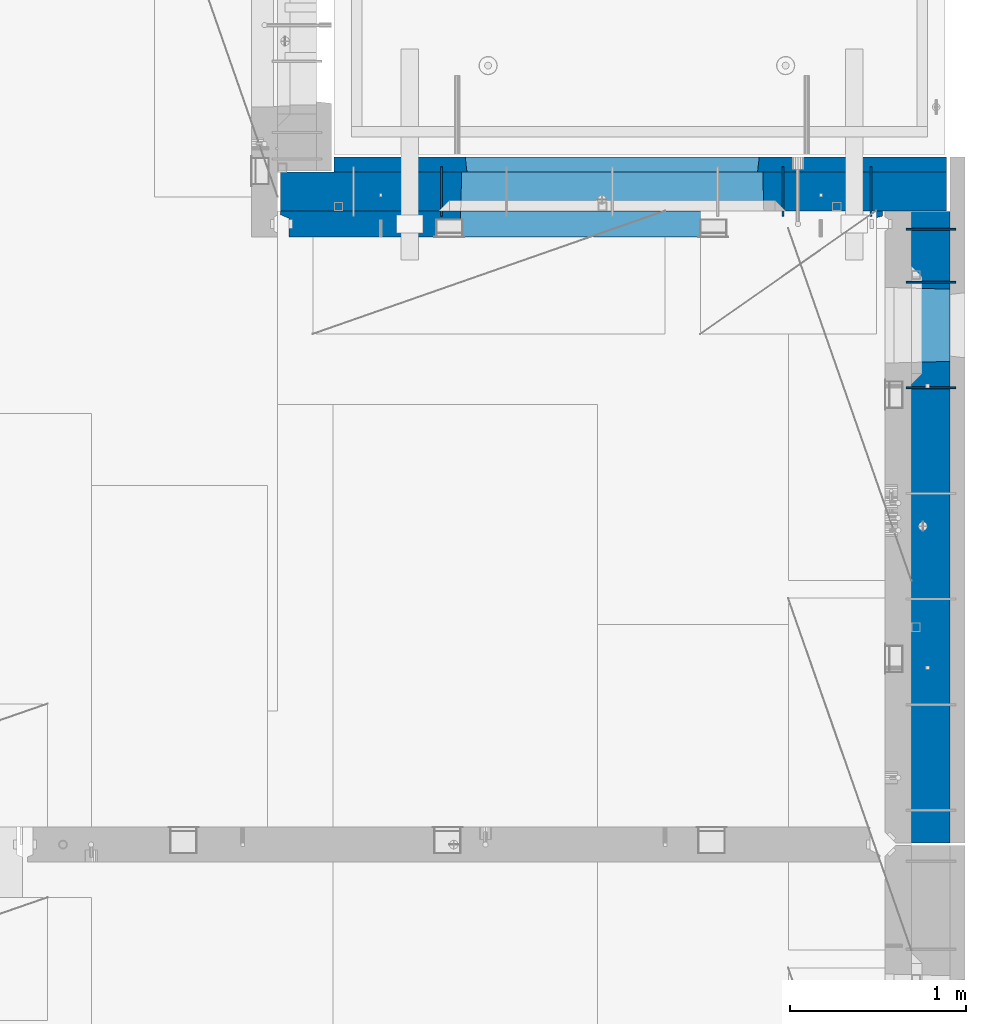
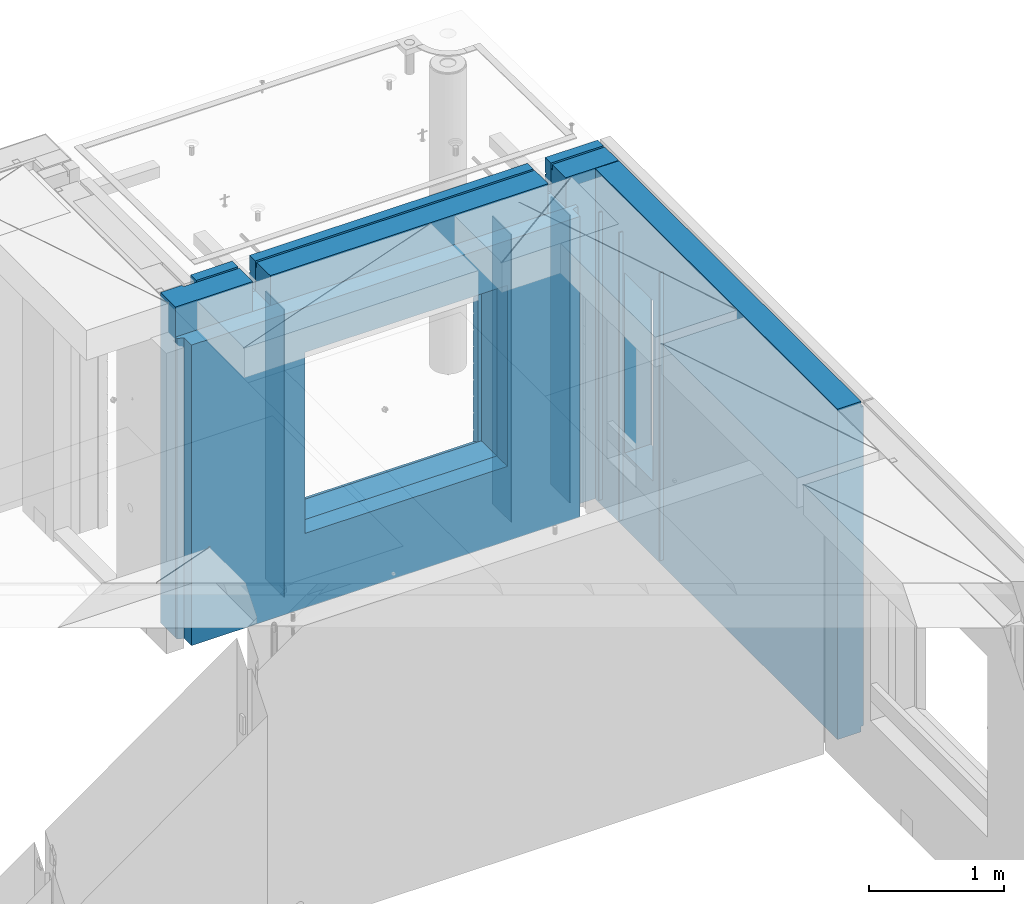
# One storey, part 243 of 350: 10 walls, 2 elements without a shape of their own.
"""IFC2X3 building model written with IfcOpenShell, lengths in millimetres."""

from ifc_helpers import new_model, si_unit, frame, origin_with_axes, place, context, subcontext, project, spatial, faceted_brep, material, type_object, element, aggregate, save


model = new_model("IFC2X3")

# Units and contexts
model_context = context("Model", 3, precision=1e-05, world=origin_with_axes())
body_context = subcontext(model_context, "Body", "Model", "MODEL_VIEW")
ifc_project = project(units=[si_unit("LENGTHUNIT", "METRE", prefix="MILLI"), si_unit("AREAUNIT", "SQUARE_METRE"), si_unit("VOLUMEUNIT", "CUBIC_METRE"), si_unit("MASSUNIT", "GRAM", prefix="KILO"), si_unit("TIMEUNIT", "SECOND"), si_unit("PLANEANGLEUNIT", "RADIAN"), si_unit("SOLIDANGLEUNIT", "STERADIAN"), si_unit("THERMODYNAMICTEMPERATUREUNIT", "DEGREE_CELSIUS"), si_unit("LUMINOUSINTENSITYUNIT", "LUMEN")], contexts=[model_context])

# Site, building, storey
site_placement = place(None, origin_with_axes())
site = spatial("IfcSite", under=ifc_project, at=site_placement, CompositionType="ELEMENT")
building_placement = place(site_placement, origin_with_axes())
building = spatial("IfcBuilding", under=site, at=building_placement, CompositionType="ELEMENT")
storey_placement = place(building_placement, origin_with_axes())
storey = spatial("IfcBuildingStorey", under=building, at=storey_placement, Name="2", CompositionType="ELEMENT", Elevation=0.0)

# Assembly, walls
assembly_1_placement = place(storey_placement, origin_with_axes())
assembly_1 = element("IfcElementAssembly", 1, at=assembly_1_placement, inside=storey, AssemblyPlace="NOTDEFINED", PredefinedType="REINFORCEMENT_UNIT")
ifc_material_1 = material(Name="Undefined")
wall_type_1 = type_object("IfcWallType", PredefinedType="NOTDEFINED")
wall_1_placement = place(assembly_1_placement, frame((34830.0, 20549.9951872276, 86115.0), z_axis=(0.0, 0.0, 1.0), x_axis=(0.0, 1.0, 0.0)))
wall_1 = element("IfcWall", 2, at=wall_1_placement, type_object=wall_type_1, material=ifc_material_1, Name="(PD)", context=body_context, shape_type="Brep", body=[
    faceted_brep([(0.0, 5.0, -1300.0), (0.0, 5.0, 1300.0), (280.0, 5.0, 1300.0), (280.0, 5.0, -1300.0), (0.0, -5.0, 1300.0), (280.0, -5.0, 1300.0), (0.0, -5.0, -1300.0), (280.0, -5.0, -1300.0)], [[[0, 1, 2, 3]], [[1, 4, 5, 2]], [[4, 6, 7, 5]], [[6, 0, 3, 7]], [[5, 7, 3, 2]], [[6, 4, 1, 0]]]),
])
wall_2_placement = place(assembly_1_placement, frame((34330.0, 20549.9951872276, 86115.0), z_axis=(0.0, 0.0, 1.0), x_axis=(0.0, 1.0, 0.0)))
wall_2 = element("IfcWall", 3, at=wall_2_placement, type_object=wall_type_1, material=ifc_material_1, Name="(PD)", context=body_context, shape_type="Brep", body=[
    faceted_brep([(0.0, 5.0, -1300.0), (0.0, 5.0, 1300.0), (280.0, 5.0, 1300.0), (280.0, 5.0, -1300.0), (0.0, -5.0, 1300.0), (280.0, -5.0, 1300.0), (0.0, -5.0, -1300.0), (280.0, -5.0, -1300.0)], [[[0, 1, 2, 3]], [[1, 4, 5, 2]], [[4, 6, 7, 5]], [[6, 0, 3, 7]], [[5, 7, 3, 2]], [[6, 4, 1, 0]]]),
])
wall_3_placement = place(assembly_1_placement, frame((32390.0, 20549.9951872276, 86115.0), z_axis=(0.0, 0.0, 1.0), x_axis=(0.0, 1.0, 0.0)))
wall_3 = element("IfcWall", 4, at=wall_3_placement, type_object=wall_type_1, material=ifc_material_1, Name="(PD)", context=body_context, shape_type="Brep", body=[
    faceted_brep([(0.0, 5.0, -1300.0), (0.0, 5.0, 1300.0), (280.0, 5.0, 1300.0), (280.0, 5.0, -1300.0), (0.0, -5.0, 1300.0), (280.0, -5.0, 1300.0), (0.0, -5.0, -1300.0), (280.0, -5.0, -1300.0)], [[[0, 1, 2, 3]], [[1, 4, 5, 2]], [[4, 6, 7, 5]], [[6, 0, 3, 7]], [[5, 7, 3, 2]], [[6, 4, 1, 0]]]),
])

assembly_2_placement = place(storey_placement, origin_with_axes())
assembly_2 = element("IfcElementAssembly", 5, at=assembly_2_placement, inside=storey, AssemblyPlace="NOTDEFINED", PredefinedType="REINFORCEMENT_UNIT")
wall_4_placement = place(assembly_2_placement, frame((35030.0, 20175.0002441406, 86115.0), z_axis=(0.0, 0.0, 1.0), x_axis=(1.0, 0.0, 0.0)))
wall_4 = element("IfcWall", 6, at=wall_4_placement, type_object=wall_type_1, material=ifc_material_1, Name="(PD)", context=body_context, shape_type="Brep", body=[
    faceted_brep([(0.0, 5.0, -1300.0), (0.0, 5.0, 1300.0), (280.0, 5.0, 1300.0), (280.0, 5.0, -1300.0), (0.0, -5.0, 1300.0), (280.0, -5.0, 1300.0), (0.0, -5.0, -1300.0), (280.0, -5.0, -1300.0)], [[[0, 1, 2, 3]], [[1, 4, 5, 2]], [[4, 6, 7, 5]], [[6, 0, 3, 7]], [[5, 7, 3, 2]], [[6, 4, 1, 0]]]),
])
wall_5_placement = place(assembly_2_placement, frame((35030.0, 20475.0002441406, 86115.0), z_axis=(0.0, 0.0, 1.0), x_axis=(1.0, 0.0, 0.0)))
wall_5 = element("IfcWall", 7, at=wall_5_placement, type_object=wall_type_1, material=ifc_material_1, Name="(PD)", context=body_context, shape_type="Brep", body=[
    faceted_brep([(0.0, 5.0, -1300.0), (0.0, 5.0, 1300.0), (280.0, 5.0, 1300.0), (280.0, 5.0, -1300.0), (0.0, -5.0, 1300.0), (280.0, -5.0, 1300.0), (0.0, -5.0, -1300.0), (280.0, -5.0, -1300.0)], [[[0, 1, 2, 3]], [[1, 4, 5, 2]], [[4, 6, 7, 5]], [[6, 0, 3, 7]], [[5, 7, 3, 2]], [[6, 4, 1, 0]]]),
])
wall_6_placement = place(assembly_2_placement, frame((35030.0, 19575.0002441406, 86115.0), z_axis=(0.0, 0.0, 1.0), x_axis=(1.0, 0.0, 0.0)))
wall_6 = element("IfcWall", 8, at=wall_6_placement, type_object=wall_type_1, material=ifc_material_1, Name="(PD)", context=body_context, shape_type="Brep", body=[
    faceted_brep([(0.0, 5.0, -1300.0), (0.0, 5.0, 1300.0), (280.0, 5.0, 1300.0), (280.0, 5.0, -1300.0), (0.0, -5.0, 1300.0), (280.0, -5.0, 1300.0), (0.0, -5.0, -1300.0), (280.0, -5.0, -1300.0)], [[[0, 1, 2, 3]], [[1, 4, 5, 2]], [[4, 6, 7, 5]], [[6, 0, 3, 7]], [[5, 7, 3, 2]], [[6, 4, 1, 0]]]),
])
ifc_material_2 = material(Name="COS5gt")
wall_type_2 = type_object("IfcWallType", PredefinedType="NOTDEFINED")
wall_7_placement = place(assembly_2_placement, frame((35170.0, 20575.0002441406, 86247.5), z_axis=(0.0, 0.0, 1.0), x_axis=(0.0, -1.0, 0.0)))
wall_7 = element("IfcWall", 9, at=wall_7_placement, type_object=wall_type_2, material=ifc_material_2, context=body_context, shape_type="Brep", body=[
    faceted_brep([(0.0, 90.0, 1492.5), (3585.0, 90.0, 1492.5), (3585.0, 90.0, 1442.5), (0.0, 90.0, 1442.5), (0.0, -110.0, 1492.5), (3585.0, -110.0, 1492.5), (3585.0, 110.0, 1442.5), (3585.0, -110.0, -1492.5), (3585.0, 90.0, -1492.5), (3585.0, 90.0, -1442.5), (3585.0, 110.0, -1442.5), (0.0, 110.0, 1442.5), (0.0, 90.0, -1492.5), (0.0, -110.0, -1492.5), (0.0, 110.0, -1442.5), (0.0, 90.0, -1442.5), (440.000277665298, 110.0, -807.5), (470.000277665298, 110.0, -807.5), (820.000277665298, 110.0, -807.5), (850.000277665298, 110.0, -807.5), (850.000277665298, 110.0, -802.5), (850.000277665298, 110.0, 807.5), (440.000277665298, 110.0, 807.5), (440.000277665298, 110.0, -802.5), (855.946223611245, -110.0, -813.445945945947), (855.946223611245, -110.0, 813.445945945947), (434.054331719351, -110.0, -813.445945945947), (434.054331719351, -110.0, 813.445945945947)], [[[0, 1, 2, 3]], [[4, 5, 1, 0]], [[6, 2, 1, 5, 7, 8, 9, 10]], [[11, 3, 2, 6]], [[12, 13, 4, 0, 3, 11, 14, 15]], [[7, 13, 12, 8]], [[15, 9, 8, 12]], [[14, 10, 9, 15]], [[11, 6, 10, 14], [16, 17, 18, 19, 20, 21, 22, 23]], [[20, 19, 24, 25, 21]], [[18, 17, 16, 26, 24, 19]], [[23, 22, 27, 26, 16]], [[21, 25, 27, 22]], [[4, 13, 7, 5], [24, 26, 27, 25]]]),
])
aggregate(assembly_2, [wall_4, wall_5, wall_6, wall_7])

# Wall
wall_8_placement = place(assembly_1_placement, frame((31475.0, 20689.9951872276, 86247.5), z_axis=(0.0, 0.0, 1.0), x_axis=(1.0, 0.0, 0.0)))
wall_8 = element("IfcWall", 10, at=wall_8_placement, type_object=wall_type_2, material=ifc_material_2, context=body_context, shape_type="Brep", body=[
    faceted_brep([(810.0, 110.0, 1442.5), (810.0, 90.0, 1442.5), (3185.0, 90.0, 1442.5), (3185.0, 110.0, 1442.5), (810.0, 90.0, 1492.5), (810.0, -110.0, 1492.5), (3185.0, -110.0, 1492.5), (3185.0, 90.0, 1492.5), (184.0, 90.0, 1442.5), (184.0, 90.0, 1492.5), (660.0, 90.0, 1492.5), (660.0, 90.0, 1442.5), (184.0, 110.0, 1492.5), (184.0, 110.0, 1442.5), (0.0, 110.0, 1492.5), (0.0, -110.0, 1492.5), (660.0, -110.0, 1492.5), (0.0, -110.0, -1492.5), (0.0, 110.0, -1492.5), (3785.0, 90.0, -1492.5), (184.0, 90.0, -1492.5), (184.0, 90.0, -1442.5), (3785.0, 90.0, -1442.5), (3785.0, -110.0, -1492.5), (184.0, 110.0, -1492.5), (184.0, 110.0, -1442.5), (3785.0, 110.0, -1442.5), (3785.0, 110.0, 1442.5), (3785.0, 90.0, 1442.5), (3785.0, 90.0, 1492.5), (3785.0, -110.0, 1492.5), (3335.0, 90.0, 1492.5), (3335.0, -110.0, 1492.5), (3185.0, -110.000000000004, 1222.5), (810.0, -110.0, 1222.5), (660.0, -110.0, 1222.5), (3335.0, -110.000000000004, 1222.5), (1024.05429979644, -110.000000000004, -813.445945945947), (1024.05429979644, -110.000000000004, 813.445945945947), (2745.94619168834, -110.000000000004, 813.445945945947), (2745.94619168834, -110.000000000004, -813.445945945947), (1030.00024574239, 110.0, -802.5), (1030.00024574239, 110.0, 807.5), (1030.00024574239, 110.0, -807.5), (2740.00024574239, 110.0, -807.5), (2710.00024574239, 110.0, -807.5), (1060.00024574239, 110.0, -807.5), (2740.00024574239, 110.0, 807.5), (2740.00024574239, 110.0, -802.5), (660.0, 110.0, 1442.5), (660.0, 109.999999999996, 1222.5), (810.0, 109.999999999996, 1222.5), (3185.0, 109.999999999996, 1222.5), (3335.0, 109.999999999996, 1222.5), (3335.0, 110.0, 1442.5), (3335.0, 90.0, 1442.5)], [[[0, 1, 2, 3]], [[4, 5, 6, 7]], [[8, 9, 10, 11]], [[12, 9, 8, 13]], [[9, 12, 14, 15, 16, 10]], [[17, 15, 14, 18]], [[19, 20, 21, 22]], [[23, 17, 18, 24, 20, 19]], [[25, 21, 20, 24]], [[26, 22, 21, 25]], [[27, 28, 29, 30, 23, 19, 22, 26]], [[30, 29, 31, 32]], [[33, 6, 5, 34, 35, 16, 15, 17, 23, 30, 32, 36], [37, 38, 39, 40]], [[41, 42, 38, 37, 43]], [[40, 44, 45, 46, 43, 37]], [[39, 47, 48, 44, 40]], [[38, 42, 47, 39]], [[27, 26, 25, 24, 18, 14, 12, 13, 49, 50, 51, 0, 3, 52, 53, 54], [41, 43, 46, 45, 44, 48, 47, 42]], [[28, 27, 54, 55]], [[29, 28, 55, 31]], [[54, 53, 36, 32, 31, 55]], [[52, 33, 36, 53]], [[3, 2, 7, 6, 33, 52]], [[1, 4, 7, 2]], [[0, 51, 34, 5, 4, 1]], [[50, 35, 34, 51]], [[49, 11, 10, 16, 35, 50]], [[13, 8, 11, 49]]]),
])

ifc_material_3 = material(Name="CONCRETE/C30/37")
wall_type_3 = type_object("IfcWallType", PredefinedType="NOTDEFINED")
wall_9_placement = place(assembly_1_placement, frame((31780.0, 20842.4951872276, 86247.5), z_axis=(0.0, 0.0, 1.0), x_axis=(1.0, 0.0, 0.0)))
wall_9 = element("IfcWall", 11, at=wall_9_placement, type_object=wall_type_3, material=ifc_material_3, context=body_context, shape_type="Brep", body=[
    faceted_brep([(3480.0, -42.5, 1492.5), (3480.0, 42.5, 1492.5), (3030.0, 42.5, 1492.5), (3030.0, -42.5, 1492.5), (3480.0, 42.4999992431694, 1356.99999988925), (3030.0, 42.4999993410347, 1356.99999988925), (3480.0, 32.4999991127006, 1355.00000040044), (3480.0, 32.4999992507037, 1344.99999999926), (3030.0, 32.4999992507037, 1344.99999999926), (3030.0, 32.4999991127006, 1355.00000040044), (3480.0, 42.4999996036895, 1342.99999994476), (3030.0, 42.4999996549377, 1342.99999994476), (3480.0, 42.4999993831152, 892.999999944761), (0.0, 42.5, 892.999999944761), (0.0, 32.4999992507037, 894.999999999258), (3480.0, 32.4999992507037, 894.999999999258), (0.0, 32.4999991127006, 905.00000040044), (3480.0, 32.4999991127006, 905.00000040044), (3480.0, 42.4999992431694, 906.999999889245), (0.0, 42.5, 906.999999889245), (0.0, 42.5, 1042.99999994476), (3480.0, 42.4999994189675, 1042.99999994476), (0.0, 32.4999992507037, 1044.99999999926), (3480.0, 32.4999992507037, 1044.99999999926), (0.0, 32.4999991127006, 1055.00000040044), (3480.0, 32.4999991127006, 1055.00000040044), (3480.0, 42.4999992431694, 1056.99999988925), (0.0, 42.5, 1056.99999988925), (0.0, 42.5, 1192.99999994476), (3480.0, 42.4999994795144, 1192.99999994476), (0.0, 32.4999992507037, 1194.99999999926), (3480.0, 32.4999992507037, 1194.99999999926), (0.0, 32.4999991127006, 1205.00000040044), (3480.0, 32.4999991127006, 1205.00000040044), (3480.0, 42.4999992431694, 1206.99999988925), (0.0, 42.5, 1206.99999988925), (-3.63797880709171e-12, 32.4999992507037, 1344.99999999926), (-3.63797880709171e-12, 32.4999991127006, 1355.00000040044), (355.0, 32.4999991127006, 1355.00000040044), (355.0, 32.4999992507037, 1344.99999999926), (0.0, 42.5, 1342.99999994476), (355.0, 42.4999999595711, 1342.99999994476), (505.0, 32.4999992507037, 1344.99999999926), (505.0, 32.4999991127006, 1355.00000040044), (2880.0, 32.4999991127006, 1355.00000040044), (2880.0, 32.4999992507037, 1344.99999999926), (505.0, 42.4999999424908, 1342.99999994476), (2880.0, 42.4999996720217, 1342.99999994476), (355.0, 42.4999998715975, 1222.5), (505.0, 42.4999998467429, 1222.5), (2880.0, 42.4999994331811, 1222.5), (3030.0, 42.4999994081736, 1222.5), (355.0, -42.5, 1222.5), (505.0, -42.5, 1222.5), (505.0, 42.5, 1492.5), (505.0, 42.4999998901731, 1356.99999988925), (505.0, -42.5, 1492.5), (2880.0, -42.5, 1492.5), (2880.0, 42.5, 1492.5), (2880.0, 42.4999993736565, 1356.99999988925), (2880.0, -42.5000000000036, 1222.5), (3030.0, -42.5000000000036, 1222.5), (3480.0, -42.5, -1492.5), (3480.0, 42.5, -1492.5), (3480.0, 42.5, -1357.00000005524), (3480.0, 32.4999992507037, -1355.00000000074), (3480.0, 32.4999991127006, -1344.99999959956), (3480.0, 42.4999992431694, -1343.00000011075), (3480.0, 42.4999992794692, -1207.00000005524), (3480.0, 32.4999992507037, -1205.00000000074), (3480.0, 32.4999991127006, -1194.99999959956), (3480.0, 42.4999992431694, -1193.00000011075), (3480.0, 42.4999992814955, -1057.00000005524), (3480.0, 32.4999992507037, -1055.00000000074), (3480.0, 32.4999991127006, -1044.99999959956), (3480.0, 42.4999992431694, -1043.00000011075), (3480.0, 42.4999992837656, -907.000000055239), (3480.0, 32.4999992507037, -905.000000000742), (3480.0, 32.4999991127006, -894.99999959956), (3480.0, 42.4999992431694, -893.000000110755), (3480.0, 42.4999992863159, -757.000000055239), (3480.0, 32.4999992507037, -755.000000000742), (3480.0, 32.4999991127006, -744.99999959956), (3480.0, 42.4999992431694, -743.000000110755), (3480.0, 42.4999992892117, -607.000000055239), (3480.0, 32.4999992507037, -605.000000000742), (3480.0, 32.4999991127006, -594.99999959956), (3480.0, 42.4999992431694, -593.000000110755), (3480.0, 42.4999992925223, -457.000000055239), (3480.0, 32.4999992507037, -455.000000000742), (3480.0, 32.4999991127006, -444.99999959956), (3480.0, 42.4999992431694, -443.000000110755), (3480.0, 42.4999992963494, -307.000000055239), (3480.0, 32.4999992507037, -305.000000000742), (3480.0, 32.4999991127006, -294.99999959956), (3480.0, 42.4999992431694, -293.000000110755), (3480.0, 42.4999993008169, -157.000000055239), (3480.0, 32.4999992507037, -155.000000000742), (3480.0, 32.4999991127006, -144.99999959956), (3480.0, 42.4999992431694, -143.000000110755), (3480.0, 42.4999993061028, -7.00000005523907), (3480.0, 32.4999992507037, -5.00000000074215), (3480.0, 32.4999991127006, 5.0000004004396), (3480.0, 42.4999992431694, 6.99999988924537), (3480.0, 42.4999993124584, 142.999999944761), (3480.0, 32.4999992507037, 144.999999999258), (3480.0, 32.4999991127006, 155.00000040044), (3480.0, 42.4999992431694, 156.999999889245), (3480.0, 42.49999932024, 292.999999944761), (3480.0, 32.4999992507037, 294.999999999258), (3480.0, 32.4999991127006, 305.00000040044), (3480.0, 42.4999992431694, 306.999999889245), (3480.0, 42.4999993299934, 442.999999944761), (3480.0, 32.4999992507037, 444.999999999258), (3480.0, 32.4999991127006, 455.00000040044), (3480.0, 42.4999992431694, 456.999999889245), (3480.0, 42.4999993425699, 592.999999944761), (3480.0, 32.4999992507037, 594.999999999258), (3480.0, 32.4999991127006, 605.00000040044), (3480.0, 42.4999992431694, 606.999999889245), (3480.0, 42.4999993594065, 742.999999944761), (3480.0, 32.4999992507037, 744.999999999258), (3480.0, 32.4999991127006, 755.00000040044), (3480.0, 42.4999992431694, 756.999999889245), (0.0, -42.5, -1492.5), (0.0, 42.5, -1492.5), (0.0, 42.5, -1357.00000005524), (0.0, 32.4999992507037, -1355.00000000074), (0.0, 32.4999991127006, -1344.99999959956), (0.0, 42.5, -1343.00000011075), (0.0, 42.5, -1207.00000005524), (0.0, 32.4999992507037, -1205.00000000074), (0.0, 32.4999991127006, -1194.99999959956), (0.0, 42.5, -1193.00000011075), (0.0, 42.5, -1057.00000005524), (0.0, 32.4999992507037, -1055.00000000074), (0.0, 32.4999991127006, -1044.99999959956), (0.0, 42.5, -1043.00000011075), (0.0, 42.5, -907.000000055239), (0.0, 32.4999992507037, -905.000000000742), (0.0, 32.4999991127006, -894.99999959956), (0.0, 42.5, -893.000000110755), (0.0, 32.4999991127006, 755.00000040044), (0.0, 42.5, 756.999999889245), (745.000245742391, 42.4999998379753, 756.999999889245), (746.176716435013, 32.4999991127006, 755.00000040044), (0.0, 32.4999992507037, 744.999999999258), (746.17671641878, 32.4999992507037, 744.999999999258), (0.0, 42.5, 742.999999944761), (745.000245742391, 42.4999998628628, 742.999999944761), (0.0, 42.5, 606.999999889245), (745.000245742391, 42.4999998379753, 606.999999889245), (3.63797880709171e-12, 32.4999991127006, 605.00000040044), (746.176716435013, 32.4999991127006, 605.00000040044), (3.63797880709171e-12, 32.4999992507037, 594.999999999258), (746.176716418777, 32.4999992507037, 594.999999999258), (0.0, 42.5, 592.999999944761), (745.000245742391, 42.4999998592575, 592.999999944761), (0.0, 42.5, 456.999999889245), (745.000245742391, 42.4999998379753, 456.999999889245), (0.0, 32.4999991127006, 455.00000040044), (746.176716435013, 32.4999991127006, 455.00000040044), (0.0, 32.4999992507037, 444.999999999258), (746.17671641878, 32.4999992507037, 444.999999999258), (0.0, 42.5, 442.999999944761), (745.000245742391, 42.4999998565654, 442.999999944761), (0.0, 42.5, 306.999999889245), (745.000245742391, 42.4999998379753, 306.999999889245), (-3.63797880709171e-12, 32.4999991127006, 305.00000040044), (746.176716435013, 32.4999991127006, 305.00000040044), (-3.63797880709171e-12, 32.4999992507037, 294.999999999258), (746.176716418777, 32.4999992507037, 294.999999999258), (0.0, 42.5, 292.999999944761), (745.000245742391, 42.4999998544772, 292.999999944761), (0.0, 42.5, 156.999999889245), (745.000245742391, 42.4999998379753, 156.999999889245), (-3.63797880709171e-12, 32.4999991127006, 155.00000040044), (746.176716435013, 32.4999991127006, 155.00000040044), (-3.63797880709171e-12, 32.4999992507037, 144.999999999258), (746.176716418777, 32.4999992507037, 144.999999999258), (0.0, 42.5, 142.999999944761), (745.000245742391, 42.499999852811, 142.999999944761), (0.0, 42.5, 6.99999988924537), (745.000245742391, 42.4999998379753, 6.99999988924537), (0.0, 32.4999991127006, 5.0000004004396), (746.176716435013, 32.4999991127006, 5.0000004004396), (0.0, 32.4999992507037, -5.00000000074215), (746.17671641878, 32.4999992507037, -5.00000000074215), (0.0, 42.5, -7.00000005523907), (745.000245742391, 42.4999998514504, -7.00000005523907), (0.0, 42.5, -143.000000110755), (745.000245742391, 42.4999998379753, -143.000000110755), (3.63797880709171e-12, 32.4999991127006, -144.99999959956), (746.176716435013, 32.4999991127006, -144.99999959956), (3.63797880709171e-12, 32.4999992507037, -155.000000000742), (746.176716418777, 32.4999992507037, -155.000000000742), (0.0, 42.5, -157.000000055239), (745.000245742391, 42.499999850319, -157.000000055239), (0.0, 42.5, -293.000000110755), (745.000245742391, 42.4999998379753, -293.000000110755), (0.0, 32.4999991127006, -294.99999959956), (746.176716435013, 32.4999991127006, -294.99999959956), (0.0, 32.4999992507037, -305.000000000742), (746.17671641878, 32.4999992507037, -305.000000000742), (0.0, 42.5, -307.000000055239), (745.000245742391, 42.4999998493622, -307.000000055239), (0.0, 42.5, -443.000000110755), (745.000245742391, 42.4999998379753, -443.000000110755), (0.0, 32.4999991127006, -444.99999959956), (746.176716435013, 32.4999991127006, -444.99999959956), (0.0, 32.4999992507037, -455.000000000742), (746.17671641878, 32.4999992507037, -455.000000000742), (0.0, 42.5, -457.000000055239), (745.000245742391, 42.4999998485437, -457.000000055239), (0.0, 42.5, -593.000000110755), (745.000245742391, 42.4999998379753, -593.000000110755), (3.63797880709171e-12, 32.4999991127006, -594.99999959956), (746.176716435013, 32.4999991127006, -594.99999959956), (3.63797880709171e-12, 32.4999992507037, -605.000000000742), (746.176716418777, 32.4999992507037, -605.000000000742), (0.0, 42.5, -607.000000055239), (745.000245742391, 42.4999998478343, -607.000000055239), (0.0, 42.5, -743.000000110755), (745.000245742391, 42.4999998379753, -743.000000110755), (0.0, 32.4999991127006, -744.99999959956), (746.176716435013, 32.4999991127006, -744.99999959956), (0.0, 32.4999992507037, -755.000000000742), (746.17671641878, 32.4999992507037, -755.000000000742), (0.0, 42.5, -757.000000055239), (745.000245742391, 42.4999998472158, -757.000000055239), (745.000245742391, 42.5, -857.5), (755.000245742391, -42.5, -807.5), (2405.00024574239, -42.5, -807.5), (2415.00024574239, 42.5, -857.5), (2415.00024574239, 42.4999995047292, -757.000000055239), (2413.823775066, 32.4999992507037, -755.000000000742), (2413.82377504977, 32.4999991127006, -744.99999959956), (2415.00024574239, 42.499999474785, -743.000000110755), (2415.00024574239, 42.4999995067374, -607.000000055239), (2413.823775066, 32.4999992507037, -605.000000000742), (2413.82377504977, 32.4999991127006, -594.99999959956), (2415.00024574239, 42.499999474785, -593.000000110755), (2415.00024574239, 42.4999995090366, -457.000000055239), (2413.823775066, 32.4999992507037, -455.000000000742), (2413.82377504977, 32.4999991127006, -444.99999959956), (2415.00024574239, 42.499999474785, -443.000000110755), (2415.00024574239, 42.4999995116923, -307.000000055239), (2413.823775066, 32.4999992507037, -305.000000000742), (2413.82377504977, 32.4999991127006, -294.99999959956), (2415.00024574239, 42.499999474785, -293.000000110755), (2415.00024574239, 42.4999995147919, -157.000000055239), (2413.823775066, 32.4999992507037, -155.000000000742), (2413.82377504977, 32.4999991127006, -144.99999959956), (2415.00024574239, 42.499999474785, -143.000000110755), (2415.00024574239, 42.4999995184589, -7.00000005523907), (2413.823775066, 32.4999992507037, -5.00000000074215), (2413.82377504977, 32.4999991127006, 5.0000004004396), (2415.00024574239, 42.499999474785, 6.99999988924537), (2415.00024574239, 42.4999995228682, 142.999999944761), (2413.823775066, 32.4999992507037, 144.999999999258), (2413.82377504977, 32.4999991127006, 155.00000040044), (2415.00024574239, 42.499999474785, 156.999999889245), (2415.00024574239, 42.4999995282706, 292.999999944761), (2413.823775066, 32.4999992507037, 294.999999999258), (2413.82377504977, 32.4999991127006, 305.00000040044), (2415.00024574239, 42.499999474785, 306.999999889245), (2415.00024574239, 42.4999995350372, 442.999999944761), (2413.823775066, 32.4999992507037, 444.999999999258), (2413.82377504977, 32.4999991127006, 455.00000040044), (2415.00024574239, 42.499999474785, 456.999999889245), (2415.00024574239, 42.4999995437647, 592.999999944761), (2413.823775066, 32.4999992507037, 594.999999999258), (2413.82377504977, 32.4999991127006, 605.00000040044), (2415.00024574239, 42.499999474785, 606.999999889245), (2415.00024574239, 42.4999995554499, 742.999999944761), (2413.823775066, 32.4999992507037, 744.999999999258), (2413.82377504977, 32.4999991127006, 755.00000040044), (2415.00024574239, 42.499999474785, 756.999999889245), (755.000245742391, 42.5, 782.5), (745.000245742391, 42.5, 782.5), (2415.00024574239, 42.5, 782.5), (2405.00024574239, 42.5, 782.5), (755.000245742391, -42.5, 782.5), (755.000245742391, -42.5, 787.5), (2405.00024574239, -42.5, 787.5), (2405.00024574239, -42.5, 782.5), (355.0, -42.5, 1492.5), (0.0, -42.5, 1492.5), (0.0, 42.5, 1492.5), (355.0, 42.5, 1492.5), (0.0, 42.5, 1356.99999988925), (355.0, 42.4999999227948, 1356.99999988925)], [[[0, 1, 2, 3]], [[1, 4, 5, 2]], [[6, 7, 8, 9]], [[7, 10, 11, 8]], [[12, 13, 14, 15]], [[15, 14, 16, 17]], [[18, 17, 16, 19]], [[18, 19, 20, 21]], [[21, 20, 22, 23]], [[23, 22, 24, 25]], [[26, 25, 24, 27]], [[26, 27, 28, 29]], [[29, 28, 30, 31]], [[31, 30, 32, 33]], [[34, 33, 32, 35]], [[36, 37, 38, 39]], [[40, 36, 39, 41]], [[42, 43, 44, 45]], [[46, 42, 45, 47]], [[10, 34, 35, 40, 41, 48, 49, 46, 47, 50, 51, 11]], [[48, 52, 53, 49]], [[54, 55, 43, 42, 46, 49, 53, 56]], [[54, 56, 57, 58]], [[55, 54, 58, 59]], [[43, 55, 59, 44]], [[58, 57, 60, 50, 47, 45, 44, 59]], [[50, 60, 61, 51]], [[2, 5, 9, 8, 11, 51, 61, 3]], [[4, 6, 9, 5]], [[1, 0, 62, 63, 64, 65, 66, 67, 68, 69, 70, 71, 72, 73, 74, 75, 76, 77, 78, 79, 80, 81, 82, 83, 84, 85, 86, 87, 88, 89, 90, 91, 92, 93, 94, 95, 96, 97, 98, 99, 100, 101, 102, 103, 104, 105, 106, 107, 108, 109, 110, 111, 112, 113, 114, 115, 116, 117, 118, 119, 120, 121, 122, 123, 12, 15, 17, 18, 21, 23, 25, 26, 29, 31, 33, 34, 10, 7, 6, 4]], [[124, 125, 63, 62]], [[63, 125, 126, 64]], [[64, 126, 127, 65]], [[65, 127, 128, 66]], [[67, 66, 128, 129]], [[67, 129, 130, 68]], [[68, 130, 131, 69]], [[69, 131, 132, 70]], [[71, 70, 132, 133]], [[71, 133, 134, 72]], [[72, 134, 135, 73]], [[73, 135, 136, 74]], [[75, 74, 136, 137]], [[75, 137, 138, 76]], [[76, 138, 139, 77]], [[77, 139, 140, 78]], [[79, 78, 140, 141]], [[142, 143, 144, 145]], [[146, 142, 145, 147]], [[148, 146, 147, 149]], [[150, 148, 149, 151]], [[152, 150, 151, 153]], [[154, 152, 153, 155]], [[156, 154, 155, 157]], [[158, 156, 157, 159]], [[160, 158, 159, 161]], [[162, 160, 161, 163]], [[164, 162, 163, 165]], [[166, 164, 165, 167]], [[168, 166, 167, 169]], [[170, 168, 169, 171]], [[172, 170, 171, 173]], [[174, 172, 173, 175]], [[176, 174, 175, 177]], [[178, 176, 177, 179]], [[180, 178, 179, 181]], [[182, 180, 181, 183]], [[184, 182, 183, 185]], [[186, 184, 185, 187]], [[188, 186, 187, 189]], [[190, 188, 189, 191]], [[192, 190, 191, 193]], [[194, 192, 193, 195]], [[196, 194, 195, 197]], [[198, 196, 197, 199]], [[200, 198, 199, 201]], [[202, 200, 201, 203]], [[204, 202, 203, 205]], [[206, 204, 205, 207]], [[208, 206, 207, 209]], [[210, 208, 209, 211]], [[212, 210, 211, 213]], [[214, 212, 213, 215]], [[216, 214, 215, 217]], [[218, 216, 217, 219]], [[220, 218, 219, 221]], [[222, 220, 221, 223]], [[224, 222, 223, 225]], [[226, 224, 225, 227]], [[228, 226, 227, 229]], [[230, 231, 232, 233]], [[80, 79, 141, 228, 229, 230, 233, 234]], [[81, 80, 234, 235]], [[82, 81, 235, 236]], [[83, 82, 236, 237]], [[84, 83, 237, 238]], [[85, 84, 238, 239]], [[86, 85, 239, 240]], [[87, 86, 240, 241]], [[88, 87, 241, 242]], [[89, 88, 242, 243]], [[90, 89, 243, 244]], [[91, 90, 244, 245]], [[92, 91, 245, 246]], [[93, 92, 246, 247]], [[94, 93, 247, 248]], [[95, 94, 248, 249]], [[96, 95, 249, 250]], [[97, 96, 250, 251]], [[98, 97, 251, 252]], [[99, 98, 252, 253]], [[100, 99, 253, 254]], [[101, 100, 254, 255]], [[102, 101, 255, 256]], [[103, 102, 256, 257]], [[104, 103, 257, 258]], [[105, 104, 258, 259]], [[106, 105, 259, 260]], [[107, 106, 260, 261]], [[108, 107, 261, 262]], [[109, 108, 262, 263]], [[110, 109, 263, 264]], [[111, 110, 264, 265]], [[112, 111, 265, 266]], [[113, 112, 266, 267]], [[114, 113, 267, 268]], [[115, 114, 268, 269]], [[116, 115, 269, 270]], [[117, 116, 270, 271]], [[118, 117, 271, 272]], [[119, 118, 272, 273]], [[120, 119, 273, 274]], [[121, 120, 274, 275]], [[122, 121, 275, 276]], [[123, 122, 276, 277]], [[278, 279, 144, 143, 13, 12, 123, 277, 280, 281]], [[282, 231, 230, 229, 227, 225, 223, 221, 219, 217, 215, 213, 211, 209, 207, 205, 203, 201, 199, 197, 195, 193, 191, 189, 187, 185, 183, 181, 179, 177, 175, 173, 171, 169, 167, 165, 163, 161, 159, 157, 155, 153, 151, 149, 147, 145, 144, 279, 283]], [[278, 281, 280, 284, 283, 279]], [[277, 276, 275, 274, 273, 272, 271, 270, 269, 268, 267, 266, 265, 264, 263, 262, 261, 260, 259, 258, 257, 256, 255, 254, 253, 252, 251, 250, 249, 248, 247, 246, 245, 244, 243, 242, 241, 240, 239, 238, 237, 236, 235, 234, 233, 232, 285, 284, 280]], [[60, 57, 56, 53, 52, 286, 287, 124, 62, 0, 3, 61], [232, 231, 282, 283, 284, 285]], [[288, 287, 286, 289]], [[36, 40, 35, 32, 30, 28, 27, 24, 22, 20, 19, 16, 14, 13, 143, 142, 146, 148, 150, 152, 154, 156, 158, 160, 162, 164, 166, 168, 170, 172, 174, 176, 178, 180, 182, 184, 186, 188, 190, 192, 194, 196, 198, 200, 202, 204, 206, 208, 210, 212, 214, 216, 218, 220, 222, 224, 226, 228, 141, 140, 139, 138, 137, 136, 135, 134, 133, 132, 131, 130, 129, 128, 127, 126, 125, 124, 287, 288, 290, 37]], [[37, 290, 291, 38]], [[289, 286, 52, 48, 41, 39, 38, 291]], [[290, 288, 289, 291]]]),
])

ifc_material_4 = material(Name="CONCRETE/C25/30")
wall_type_4 = type_object("IfcWallType", PredefinedType="NOTDEFINED")
wall_10_placement = place(assembly_1_placement, frame((31475.0, 20504.9951872276, 86112.5), z_axis=(0.0, 0.0, 1.0), x_axis=(1.0, 0.0, 0.0)))
wall_10 = element("IfcWall", 12, at=wall_10_placement, type_object=wall_type_4, material=ifc_material_4, context=body_context, shape_type="Brep", body=[
    faceted_brep([(3370.0, -75.0, 1357.5), (3370.0, -75.0, -1357.5), (3370.0, 32.0, -1357.5), (3370.0, 32.0, 1357.5), (3420.0, 75.0, 1357.5), (0.0, 75.0, 1357.5), (0.0, 53.6645811319431, 1357.5), (49.9951872275633, 32.0, 1357.5), (49.9951872275633, -75.0, 1357.5), (3420.0, 45.0, 1357.5), (49.9951872275633, 32.0, -1357.5), (49.9951872275633, -75.0, -1357.5), (0.0, 53.6645811319431, -1357.5), (0.0, 75.0, -1357.5), (3420.0, 75.0, -1357.5), (3420.0, 45.0, -1357.5), (1020.00024574239, -75.0, 952.5), (1024.05429979644, 75.0, 948.445945945947), (2745.94619168834, 75.0, 948.445945945947), (2750.00024574239, -75.0, 952.5), (1024.05429979644, 75.0, -678.445945945947), (2745.94619168834, 75.0, -678.445945945947), (2750.00024574239, -75.0, -682.5), (1020.00024574239, -75.0, -682.5)], [[[0, 1, 2, 3]], [[4, 5, 6, 7, 8, 0, 3, 9]], [[7, 10, 11, 8]], [[6, 12, 10, 7]], [[5, 13, 12, 6]], [[1, 11, 10, 12, 13, 14, 15, 2]], [[9, 3, 2, 15]], [[14, 4, 9, 15]], [[16, 17, 18, 19]], [[13, 5, 4, 14], [20, 21, 18, 17]], [[19, 18, 21, 22]], [[8, 11, 1, 0], [23, 16, 19, 22]], [[17, 16, 23, 20]], [[22, 21, 20, 23]]]),
])

aggregate(assembly_1, [wall_1, wall_2, wall_3, wall_9, wall_8, wall_10])

save(model, "model.ifc")
